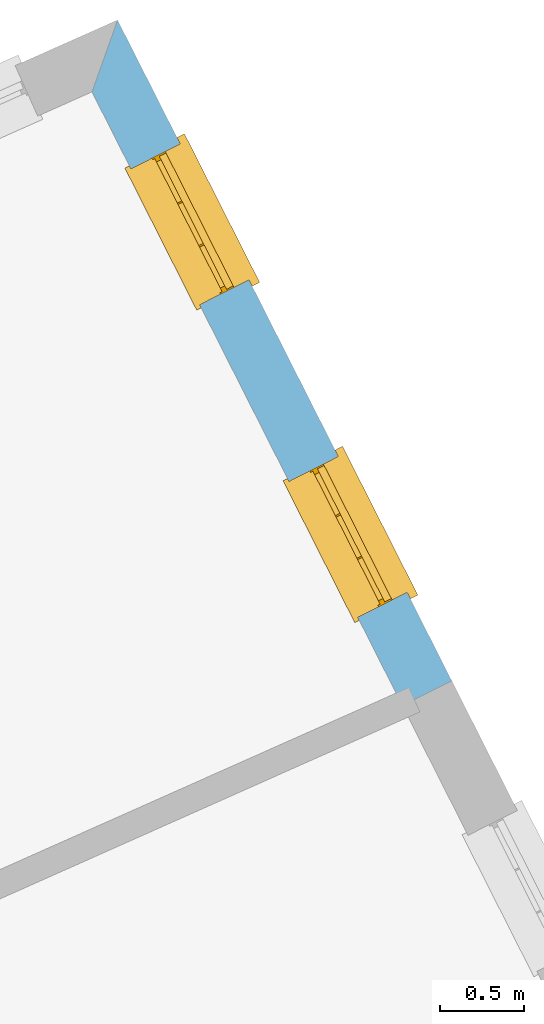
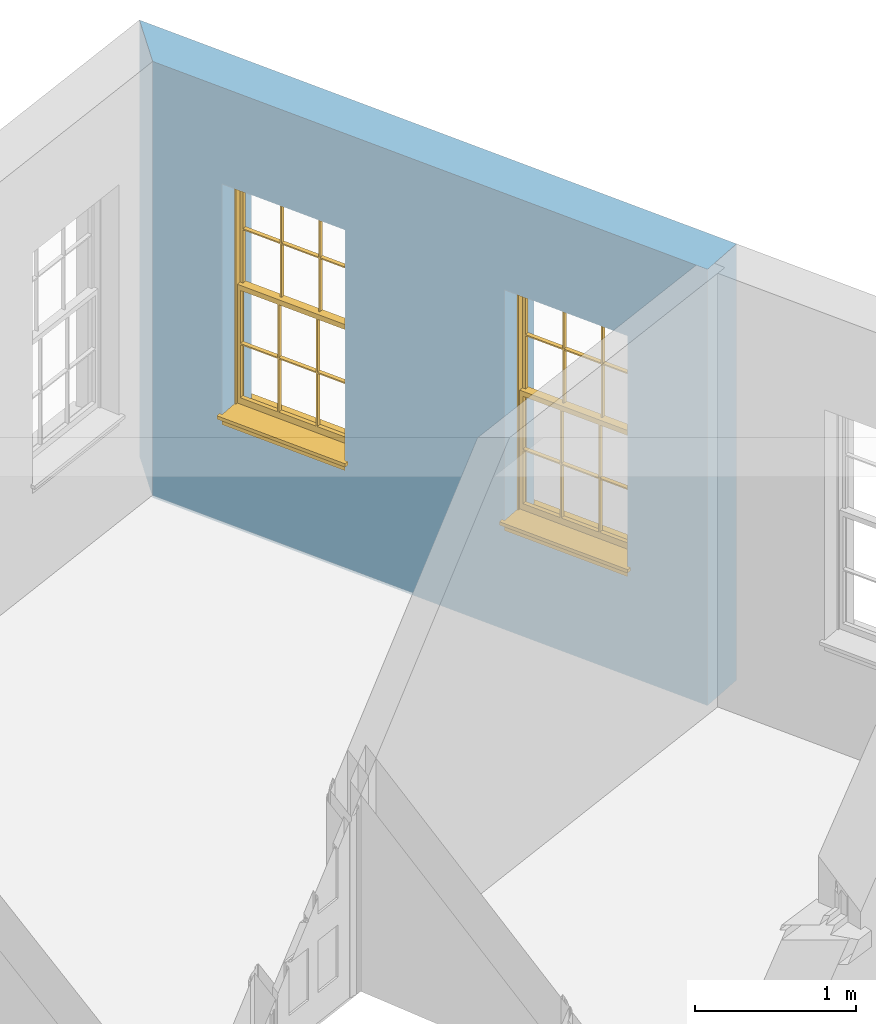
# One storey, part 8 of 8: 2 windows, 2 openings, plus 1 element that does not belong to this part.
"""IFC2X3 building model written with IfcOpenShell, lengths in metres."""

from ifc_helpers import new_model, si_unit, frame, origin, place, context, subcontext, project, spatial, polyline, outline, extrude, faceted_brep, material, layer, layer_set, layer_usage, element, fill, save


model = new_model("IFC2X3")

# Units and contexts
model_context = context("Model", 3, world=origin())
body_context = subcontext(model_context, "Body", "Model", "MODEL_VIEW")
ifc_project = project(units=[si_unit("PLANEANGLEUNIT", "RADIAN"), si_unit("MASSUNIT", "GRAM", prefix="KILO"), si_unit("FORCEUNIT", "NEWTON", prefix="KILO"), si_unit("LENGTHUNIT", "METRE")], contexts=[model_context])

# Site, building, storey
site_placement = place(None, origin())
site = spatial("IfcSite", under=ifc_project, at=site_placement, CompositionType="ELEMENT")
building_placement = place(None, origin())
building = spatial("IfcBuilding", under=site, at=building_placement, Name="Building plot-1", CompositionType="ELEMENT")
storey_placement = place(None, frame((0.0, 0.0, 5.15)))
storey = spatial("IfcBuildingStorey", under=building, at=storey_placement, Name="Floor 1", CompositionType="ELEMENT", Elevation=5.15)

# Wall, openings, windows
ifc_material = material(Name="Masonry")
ifc_layer = layer(ifc_material, 0.33, ventilated=False)
ifc_layer_set = layer_set([ifc_layer], Name="My Wall")
ifc_layer_usage = layer_usage(ifc_layer_set, "AXIS2", "NEGATIVE", 0.08)
wall_placement = place(storey_placement, origin())
wall = element("IfcWallStandardCase", 1, at=wall_placement, inside=storey, material=ifc_layer_usage, Name="exterior", context=body_context, shape_type="SweptSolid", body=[
    extrude(outline(polyline([(31.083799749939, 47.0080028311663), (31.3782721430408, 47.1569525196551), (29.383242432719, 51.1011109738831), (29.2305507452247, 50.6718619165302), (31.083799749939, 47.0080028311663)])), origin(), (0.0, 0.0, 1.0), 3.3),
])
opening_1_placement = place(storey_placement, frame((0.0, 0.0, 0.75)))
opening_1 = element("IfcOpeningElement", 2, at=opening_1_placement, cuts=wall, Name="Opening", ObjectType="Opening", context=body_context, shape_type="SweptSolid", body=[
    extrude(outline(polyline([(31.111737146863, 47.6838901652868), (30.7009970967879, 48.4959200977797), (30.4065247036861, 48.3469704092909), (30.8172647537612, 47.5349404767981), (31.111737146863, 47.6838901652868)])), origin(), (0.0, 0.0, 1.0), 1.82),
])
opening_2_placement = place(storey_placement, frame((0.0, 0.0, 0.75)))
opening_2 = element("IfcOpeningElement", 3, at=opening_2_placement, cuts=wall, Name="Opening", ObjectType="Opening", context=body_context, shape_type="SweptSolid", body=[
    extrude(outline(polyline([(30.1679271044322, 49.5497953890432), (29.7571870543571, 50.3618253215361), (29.4627146612553, 50.2128756330473), (29.8734547113304, 49.4008457005545), (30.1679271044322, 49.5497953890432)])), origin(), (0.0, 0.0, 1.0), 1.82),
])
window_1_placement = place(storey_placement, frame((30.8886520005738, 47.5710494921893, 0.75), z_axis=(0.0, 0.0, 1.0), x_axis=(-0.410740050075116, 0.81202993249282, 0.0)))
window_1 = element("IfcWindow", 4, at=window_1_placement, inside=storey, Name="living outside window", OverallHeight=1.82, OverallWidth=0.91, context=body_context, shape_type="Brep", held_by="IfcProductRepresentation", body=[
    faceted_brep([(0.033125, -0.105, 0.975209), (0.01, -0.105, 0.975209), (0.033125, -0.105, 1.376042), (0.876875, -0.105, 0.975209), (0.876875, -0.105, 1.376042), (0.9, -0.105, 0.975209), (0.876875, -0.105, 1.386042), (0.876875, -0.105, 1.786875), (0.9, -0.105, 1.81), (0.033125, -0.105, 1.786875), (0.033125, -0.105, 1.386042), (0.01, -0.105, 1.81), (0.876875, -0.135, 1.376042), (0.876875, -0.135, 0.975209), (0.9, -0.135, 0.937083), (0.033125, -0.135, 1.786875), (0.01, -0.135, 1.81), (0.033125, -0.135, 1.386042), (0.01, -0.135, 0.937083), (0.033125, -0.135, 0.975209), (0.033125, -0.135, 1.376042), (0.876875, -0.135, 1.786875), (0.876875, -0.135, 1.386042), (0.9, -0.135, 1.81), (0.033125, -0.105, 0.937083), (0.01, -0.105, 0.937083), (0.033125, -0.105, 0.53625), (0.876875, -0.105, 0.937083), (0.876875, -0.105, 0.53625), (0.9, -0.105, 0.937083), (0.876875, -0.105, 0.52625), (0.876875, -0.105, 0.125417), (0.9, -0.105, 0.077167), (0.033125, -0.105, 0.125417), (0.033125, -0.105, 0.52625), (0.01, -0.105, 0.077167), (-0.0425, -0.25, 0.01), (-0.0425, -0.3, 0.001667), (0.0, -0.25, 0.01), (0.9525, -0.25, 0.01), (0.91, -0.25, 0.01), (0.9525, -0.3, 0.001667), (-0.02, 0.08, 0.077167), (0.0, 0.08, 0.077167), (-0.02, 0.11, 0.077167), (0.0, -0.06, 0.077167), (0.01, -0.06, 0.077167), (0.91, -0.06, 0.077167), (0.91, 0.08, 0.077167), (0.9, -0.06, 0.077167), (0.93, 0.08, 0.077167), (0.93, 0.11, 0.077167), (0.01, -0.075, 0.975209), (0.9, -0.075, 0.975209), (0.876875, -0.075, 0.125417), (0.876875, -0.075, 0.52625), (0.9, -0.075, 0.077167), (0.876875, -0.075, 0.53625), (0.876875, -0.075, 0.937083), (0.033125, -0.075, 0.125417), (0.01, -0.075, 0.077167), (0.033125, -0.075, 0.52625), (0.033125, -0.075, 0.937083), (0.033125, -0.075, 0.53625), (-0.02, 0.08, 0.052167), (-0.02, 0.11, 0.052167), (0.93, 0.11, 0.052167), (0.93, 0.08, 0.052167), (0.91, 0.08, 0.052167), (0.0, 0.08, 0.052167), (0.91, -0.15, 0.026667), (0.0, -0.15, 0.026667), (-0.0425, -0.3, -0.123333), (0.9525, -0.3, -0.123333), (-0.0425, -0.25, -0.123333), (0.9525, -0.25, -0.123333), (0.01, -0.06, 1.81), (0.9, -0.06, 1.81), (0.0, -0.06, 1.82), (0.91, -0.06, 1.82), (0.01, -0.15, 0.077167), (0.9, -0.15, 0.077167), (0.592292, -0.105, 0.125417), (0.592292, -0.075, 0.125417), (0.317708, -0.075, 0.125417), (0.317708, -0.105, 0.125417), (0.592292, -0.105, 0.53625), (0.317708, -0.105, 0.53625), (0.317708, -0.105, 0.52625), (0.592292, -0.105, 0.52625), (0.592292, -0.075, 0.53625), (0.317708, -0.075, 0.53625), (0.592292, -0.135, 1.386042), (0.592292, -0.105, 1.386042), (0.317708, -0.105, 1.386042), (0.317708, -0.135, 1.386042), (0.317708, -0.135, 1.376042), (0.592292, -0.135, 1.376042), (0.317708, -0.105, 1.376042), (0.592292, -0.105, 1.376042), (0.602292, -0.135, 1.376042), (0.592292, -0.135, 0.975209), (0.602292, -0.135, 0.975209), (0.602292, -0.105, 0.975209), (0.592292, -0.105, 0.975209), (0.602292, -0.105, 1.376042), (0.602292, -0.075, 0.53625), (0.602292, -0.105, 0.53625), (0.317708, -0.075, 0.52625), (0.307708, -0.075, 0.125417), (0.307708, -0.075, 0.52625), (0.602292, -0.075, 0.52625), (0.602292, -0.075, 0.125417), (0.592292, -0.075, 0.52625), (0.307708, -0.075, 0.53625), (0.317708, -0.075, 0.937083), (0.307708, -0.075, 0.937083), (0.602292, -0.075, 0.937083), (0.592292, -0.075, 0.937083), (0.307708, -0.105, 0.52625), (0.307708, -0.105, 0.125417), (0.307708, -0.105, 0.53625), (0.307708, -0.105, 0.937083), (0.592292, -0.105, 0.937083), (0.317708, -0.105, 0.937083), (0.602292, -0.105, 0.937083), (0.602292, -0.105, 0.52625), (0.602292, -0.105, 0.125417), (0.307708, -0.135, 1.386042), (0.307708, -0.135, 1.376042), (0.307708, -0.135, 0.975209), (0.317708, -0.135, 0.975209), (0.317708, -0.135, 1.786875), (0.307708, -0.135, 1.786875), (0.602292, -0.135, 1.786875), (0.592292, -0.135, 1.786875), (0.602292, -0.135, 1.386042), (0.602292, -0.105, 1.386042), (0.307708, -0.105, 1.386042), (0.307708, -0.105, 1.786875), (0.317708, -0.105, 1.786875), (0.592292, -0.105, 1.786875), (0.602292, -0.105, 1.786875), (0.307708, -0.105, 1.376042), (0.317708, -0.105, 0.975209), (0.307708, -0.105, 0.975209), (0.91, -0.15, 1.82), (0.9, -0.15, 1.81), (0.01, -0.15, 1.81), (0.0, -0.15, 1.82), (0.91, -0.25, 0.0), (0.0, -0.25, 0.0), (0.91, 0.08, 0.0), (0.0, 0.08, 0.0)], [[[0, 1, 2]], [[3, 4, 5]], [[6, 7, 8]], [[9, 10, 11]], [[12, 13, 14]], [[15, 16, 17]], [[18, 19, 20]], [[21, 22, 23]], [[24, 25, 26]], [[27, 28, 29]], [[30, 31, 32]], [[33, 34, 35]], [[14, 27, 29]], [[25, 24, 18]], [[36, 37, 38]], [[39, 40, 41]], [[42, 43, 44]], [[45, 46, 43]], [[47, 48, 49]], [[50, 51, 48]], [[1, 0, 52]], [[5, 53, 3]], [[54, 55, 56]], [[57, 58, 53]], [[59, 60, 61]], [[62, 63, 52]], [[48, 43, 46, 49]], [[51, 44, 43, 48]], [[64, 42, 44, 65]], [[65, 44, 51, 66]], [[66, 51, 50, 67]], [[65, 66, 68, 69]], [[60, 56, 49, 46]], [[70, 71, 38, 40]], [[37, 41, 40, 38]], [[37, 72, 73, 41]], [[74, 75, 73, 72]], [[8, 11, 76, 77]], [[76, 78, 79, 77]], [[32, 35, 80, 81]], [[81, 80, 71, 70]], [[82, 83, 84, 85]], [[86, 87, 88, 89]], [[86, 90, 91, 87]], [[92, 93, 94, 95]], [[92, 95, 96, 97]], [[96, 98, 99, 97]], [[100, 97, 101, 102]], [[103, 104, 99, 105]], [[97, 99, 104, 101]], [[102, 103, 105, 100]], [[28, 57, 106, 107]], [[108, 84, 109, 110]], [[111, 112, 83, 113]], [[114, 110, 61, 63]], [[90, 113, 108, 91]], [[115, 91, 114, 116]], [[117, 106, 90, 118]], [[111, 106, 57, 55]], [[119, 110, 109, 120]], [[34, 61, 110, 119]], [[89, 113, 83, 82]], [[88, 108, 113, 89]], [[85, 84, 108, 88]], [[121, 114, 63, 26]], [[122, 116, 114, 121]], [[123, 118, 90, 86]], [[87, 91, 115, 124]], [[107, 106, 117, 125]], [[126, 111, 55, 30]], [[127, 112, 111, 126]], [[126, 30, 28, 107]], [[88, 119, 120, 85]], [[126, 89, 82, 127]], [[125, 123, 86, 107]], [[121, 26, 34, 119]], [[124, 122, 121, 87]], [[128, 17, 20, 129]], [[96, 129, 130, 131]], [[132, 133, 128, 95]], [[134, 135, 92, 136]], [[100, 12, 22, 136]], [[137, 6, 4, 105]], [[94, 138, 139, 140]], [[137, 93, 141, 142]], [[99, 98, 94, 93]], [[143, 2, 10, 138]], [[144, 145, 143, 98]], [[129, 143, 145, 130]], [[20, 2, 143, 129]], [[131, 144, 98, 96]], [[128, 138, 10, 17]], [[133, 139, 138, 128]], [[135, 141, 93, 92]], [[95, 94, 140, 132]], [[22, 6, 137, 136]], [[136, 137, 142, 134]], [[100, 105, 4, 12]], [[107, 86, 89, 126]], [[106, 111, 113, 90]], [[91, 108, 110, 114]], [[87, 121, 119, 88]], [[97, 100, 136, 92]], [[129, 96, 95, 128]], [[98, 143, 138, 94]], [[105, 99, 93, 137]], [[131, 101, 104, 144]], [[124, 115, 118, 123]], [[132, 140, 141, 135]], [[120, 109, 59, 33]], [[15, 9, 139, 133]], [[134, 142, 7, 21]], [[31, 54, 112, 127]], [[36, 74, 72, 37]], [[39, 41, 73, 75]], [[18, 14, 101, 131]], [[23, 16, 132, 135]], [[83, 56, 60, 84]], [[52, 53, 118, 115]], [[53, 52, 144, 104]], [[11, 8, 141, 140]], [[14, 18, 124, 123]], [[2, 1, 11, 10]], [[8, 5, 4, 6]], [[57, 53, 56, 55]], [[60, 52, 63, 61]], [[26, 25, 35, 34]], [[32, 29, 28, 30]], [[14, 23, 22, 12]], [[18, 20, 17, 16]], [[19, 0, 2, 20]], [[17, 10, 9, 15]], [[12, 4, 3, 13]], [[21, 7, 6, 22]], [[27, 58, 57, 28]], [[30, 55, 54, 31]], [[33, 59, 61, 34]], [[26, 63, 62, 24]], [[5, 8, 77, 53]], [[76, 11, 1, 52]], [[46, 45, 78, 76]], [[49, 77, 79, 47]], [[70, 146, 147, 81]], [[71, 80, 148, 149]], [[19, 130, 145, 0]], [[102, 13, 3, 103]], [[116, 122, 24, 62]], [[29, 32, 81, 14]], [[80, 35, 25, 18]], [[60, 46, 76, 52]], [[77, 49, 56, 53]], [[23, 14, 81, 147]], [[16, 148, 80, 18]], [[35, 85, 120]], [[120, 33, 35]], [[127, 82, 32]], [[32, 31, 127]], [[32, 82, 85, 35]], [[102, 101, 14]], [[14, 13, 102]], [[18, 131, 130]], [[130, 19, 18]], [[134, 21, 23]], [[23, 135, 134]], [[16, 15, 133]], [[133, 132, 16]], [[11, 140, 139]], [[139, 9, 11]], [[142, 141, 8]], [[8, 7, 142]], [[23, 147, 148, 16]], [[146, 149, 148, 147]], [[52, 115, 116]], [[116, 62, 52]], [[118, 53, 117]], [[58, 117, 53]], [[27, 125, 117, 58]], [[56, 83, 112]], [[112, 54, 56]], [[109, 84, 60]], [[60, 59, 109]], [[125, 27, 14]], [[14, 123, 125]], [[122, 124, 18]], [[18, 24, 122]], [[145, 144, 52]], [[52, 0, 145]], [[103, 3, 53]], [[53, 104, 103]], [[79, 78, 149, 146]], [[78, 45, 71, 149]], [[146, 70, 47, 79]], [[150, 75, 74, 151]], [[68, 66, 67]], [[48, 68, 67, 50]], [[69, 64, 65]], [[42, 64, 69, 43]], [[69, 68, 152, 153]], [[70, 68, 48, 47]], [[150, 152, 68, 70]], [[43, 69, 71, 45]], [[69, 153, 151, 71]], [[152, 150, 151, 153]], [[38, 151, 74, 36]], [[71, 151, 38]], [[39, 75, 150, 40]], [[40, 150, 70]]]),
])
fill(opening_1, window_1)
window_2_placement = place(storey_placement, frame((29.944841958143, 49.4369547159457, 0.75), z_axis=(0.0, 0.0, 1.0), x_axis=(-0.410740050075116, 0.81202993249282, 0.0)))
window_2 = element("IfcWindow", 5, at=window_2_placement, inside=storey, Name="living outside window", OverallHeight=1.82, OverallWidth=0.91, context=body_context, shape_type="Brep", held_by="IfcProductRepresentation", body=[
    faceted_brep([(0.033125, -0.105, 0.975209), (0.01, -0.105, 0.975209), (0.033125, -0.105, 1.376042), (0.876875, -0.105, 0.975209), (0.876875, -0.105, 1.376042), (0.9, -0.105, 0.975209), (0.876875, -0.105, 1.386042), (0.876875, -0.105, 1.786875), (0.9, -0.105, 1.81), (0.033125, -0.105, 1.786875), (0.033125, -0.105, 1.386042), (0.01, -0.105, 1.81), (0.876875, -0.135, 1.376042), (0.876875, -0.135, 0.975209), (0.9, -0.135, 0.937083), (0.033125, -0.135, 1.786875), (0.01, -0.135, 1.81), (0.033125, -0.135, 1.386042), (0.01, -0.135, 0.937083), (0.033125, -0.135, 0.975209), (0.033125, -0.135, 1.376042), (0.876875, -0.135, 1.786875), (0.876875, -0.135, 1.386042), (0.9, -0.135, 1.81), (0.033125, -0.105, 0.937083), (0.01, -0.105, 0.937083), (0.033125, -0.105, 0.53625), (0.876875, -0.105, 0.937083), (0.876875, -0.105, 0.53625), (0.9, -0.105, 0.937083), (0.876875, -0.105, 0.52625), (0.876875, -0.105, 0.125417), (0.9, -0.105, 0.077167), (0.033125, -0.105, 0.125417), (0.033125, -0.105, 0.52625), (0.01, -0.105, 0.077167), (-0.0425, -0.25, 0.01), (-0.0425, -0.3, 0.001667), (0.0, -0.25, 0.01), (0.9525, -0.25, 0.01), (0.91, -0.25, 0.01), (0.9525, -0.3, 0.001667), (-0.02, 0.08, 0.077167), (0.0, 0.08, 0.077167), (-0.02, 0.11, 0.077167), (0.0, -0.06, 0.077167), (0.01, -0.06, 0.077167), (0.91, -0.06, 0.077167), (0.91, 0.08, 0.077167), (0.9, -0.06, 0.077167), (0.93, 0.08, 0.077167), (0.93, 0.11, 0.077167), (0.01, -0.075, 0.975209), (0.9, -0.075, 0.975209), (0.876875, -0.075, 0.125417), (0.876875, -0.075, 0.52625), (0.9, -0.075, 0.077167), (0.876875, -0.075, 0.53625), (0.876875, -0.075, 0.937083), (0.033125, -0.075, 0.125417), (0.01, -0.075, 0.077167), (0.033125, -0.075, 0.52625), (0.033125, -0.075, 0.937083), (0.033125, -0.075, 0.53625), (-0.02, 0.08, 0.052167), (-0.02, 0.11, 0.052167), (0.93, 0.11, 0.052167), (0.93, 0.08, 0.052167), (0.91, 0.08, 0.052167), (0.0, 0.08, 0.052167), (0.91, -0.15, 0.026667), (0.0, -0.15, 0.026667), (-0.0425, -0.3, -0.123333), (0.9525, -0.3, -0.123333), (-0.0425, -0.25, -0.123333), (0.9525, -0.25, -0.123333), (0.01, -0.06, 1.81), (0.9, -0.06, 1.81), (0.0, -0.06, 1.82), (0.91, -0.06, 1.82), (0.01, -0.15, 0.077167), (0.9, -0.15, 0.077167), (0.592292, -0.105, 0.125417), (0.592292, -0.075, 0.125417), (0.317708, -0.075, 0.125417), (0.317708, -0.105, 0.125417), (0.592292, -0.105, 0.53625), (0.317708, -0.105, 0.53625), (0.317708, -0.105, 0.52625), (0.592292, -0.105, 0.52625), (0.592292, -0.075, 0.53625), (0.317708, -0.075, 0.53625), (0.592292, -0.135, 1.386042), (0.592292, -0.105, 1.386042), (0.317708, -0.105, 1.386042), (0.317708, -0.135, 1.386042), (0.317708, -0.135, 1.376042), (0.592292, -0.135, 1.376042), (0.317708, -0.105, 1.376042), (0.592292, -0.105, 1.376042), (0.602292, -0.135, 1.376042), (0.592292, -0.135, 0.975209), (0.602292, -0.135, 0.975209), (0.602292, -0.105, 0.975209), (0.592292, -0.105, 0.975209), (0.602292, -0.105, 1.376042), (0.602292, -0.075, 0.53625), (0.602292, -0.105, 0.53625), (0.317708, -0.075, 0.52625), (0.307708, -0.075, 0.125417), (0.307708, -0.075, 0.52625), (0.602292, -0.075, 0.52625), (0.602292, -0.075, 0.125417), (0.592292, -0.075, 0.52625), (0.307708, -0.075, 0.53625), (0.317708, -0.075, 0.937083), (0.307708, -0.075, 0.937083), (0.602292, -0.075, 0.937083), (0.592292, -0.075, 0.937083), (0.307708, -0.105, 0.52625), (0.307708, -0.105, 0.125417), (0.307708, -0.105, 0.53625), (0.307708, -0.105, 0.937083), (0.592292, -0.105, 0.937083), (0.317708, -0.105, 0.937083), (0.602292, -0.105, 0.937083), (0.602292, -0.105, 0.52625), (0.602292, -0.105, 0.125417), (0.307708, -0.135, 1.386042), (0.307708, -0.135, 1.376042), (0.307708, -0.135, 0.975209), (0.317708, -0.135, 0.975209), (0.317708, -0.135, 1.786875), (0.307708, -0.135, 1.786875), (0.602292, -0.135, 1.786875), (0.592292, -0.135, 1.786875), (0.602292, -0.135, 1.386042), (0.602292, -0.105, 1.386042), (0.307708, -0.105, 1.386042), (0.307708, -0.105, 1.786875), (0.317708, -0.105, 1.786875), (0.592292, -0.105, 1.786875), (0.602292, -0.105, 1.786875), (0.307708, -0.105, 1.376042), (0.317708, -0.105, 0.975209), (0.307708, -0.105, 0.975209), (0.91, -0.15, 1.82), (0.9, -0.15, 1.81), (0.01, -0.15, 1.81), (0.0, -0.15, 1.82), (0.91, -0.25, 0.0), (0.0, -0.25, 0.0), (0.91, 0.08, 0.0), (0.0, 0.08, 0.0)], [[[0, 1, 2]], [[3, 4, 5]], [[6, 7, 8]], [[9, 10, 11]], [[12, 13, 14]], [[15, 16, 17]], [[18, 19, 20]], [[21, 22, 23]], [[24, 25, 26]], [[27, 28, 29]], [[30, 31, 32]], [[33, 34, 35]], [[14, 27, 29]], [[25, 24, 18]], [[36, 37, 38]], [[39, 40, 41]], [[42, 43, 44]], [[45, 46, 43]], [[47, 48, 49]], [[50, 51, 48]], [[1, 0, 52]], [[5, 53, 3]], [[54, 55, 56]], [[57, 58, 53]], [[59, 60, 61]], [[62, 63, 52]], [[48, 43, 46, 49]], [[51, 44, 43, 48]], [[64, 42, 44, 65]], [[65, 44, 51, 66]], [[66, 51, 50, 67]], [[65, 66, 68, 69]], [[60, 56, 49, 46]], [[70, 71, 38, 40]], [[37, 41, 40, 38]], [[37, 72, 73, 41]], [[74, 75, 73, 72]], [[8, 11, 76, 77]], [[76, 78, 79, 77]], [[32, 35, 80, 81]], [[81, 80, 71, 70]], [[82, 83, 84, 85]], [[86, 87, 88, 89]], [[86, 90, 91, 87]], [[92, 93, 94, 95]], [[92, 95, 96, 97]], [[96, 98, 99, 97]], [[100, 97, 101, 102]], [[103, 104, 99, 105]], [[97, 99, 104, 101]], [[102, 103, 105, 100]], [[28, 57, 106, 107]], [[108, 84, 109, 110]], [[111, 112, 83, 113]], [[114, 110, 61, 63]], [[90, 113, 108, 91]], [[115, 91, 114, 116]], [[117, 106, 90, 118]], [[111, 106, 57, 55]], [[119, 110, 109, 120]], [[34, 61, 110, 119]], [[89, 113, 83, 82]], [[88, 108, 113, 89]], [[85, 84, 108, 88]], [[121, 114, 63, 26]], [[122, 116, 114, 121]], [[123, 118, 90, 86]], [[87, 91, 115, 124]], [[107, 106, 117, 125]], [[126, 111, 55, 30]], [[127, 112, 111, 126]], [[126, 30, 28, 107]], [[88, 119, 120, 85]], [[126, 89, 82, 127]], [[125, 123, 86, 107]], [[121, 26, 34, 119]], [[124, 122, 121, 87]], [[128, 17, 20, 129]], [[96, 129, 130, 131]], [[132, 133, 128, 95]], [[134, 135, 92, 136]], [[100, 12, 22, 136]], [[137, 6, 4, 105]], [[94, 138, 139, 140]], [[137, 93, 141, 142]], [[99, 98, 94, 93]], [[143, 2, 10, 138]], [[144, 145, 143, 98]], [[129, 143, 145, 130]], [[20, 2, 143, 129]], [[131, 144, 98, 96]], [[128, 138, 10, 17]], [[133, 139, 138, 128]], [[135, 141, 93, 92]], [[95, 94, 140, 132]], [[22, 6, 137, 136]], [[136, 137, 142, 134]], [[100, 105, 4, 12]], [[107, 86, 89, 126]], [[106, 111, 113, 90]], [[91, 108, 110, 114]], [[87, 121, 119, 88]], [[97, 100, 136, 92]], [[129, 96, 95, 128]], [[98, 143, 138, 94]], [[105, 99, 93, 137]], [[131, 101, 104, 144]], [[124, 115, 118, 123]], [[132, 140, 141, 135]], [[120, 109, 59, 33]], [[15, 9, 139, 133]], [[134, 142, 7, 21]], [[31, 54, 112, 127]], [[36, 74, 72, 37]], [[39, 41, 73, 75]], [[18, 14, 101, 131]], [[23, 16, 132, 135]], [[83, 56, 60, 84]], [[52, 53, 118, 115]], [[53, 52, 144, 104]], [[11, 8, 141, 140]], [[14, 18, 124, 123]], [[2, 1, 11, 10]], [[8, 5, 4, 6]], [[57, 53, 56, 55]], [[60, 52, 63, 61]], [[26, 25, 35, 34]], [[32, 29, 28, 30]], [[14, 23, 22, 12]], [[18, 20, 17, 16]], [[19, 0, 2, 20]], [[17, 10, 9, 15]], [[12, 4, 3, 13]], [[21, 7, 6, 22]], [[27, 58, 57, 28]], [[30, 55, 54, 31]], [[33, 59, 61, 34]], [[26, 63, 62, 24]], [[5, 8, 77, 53]], [[76, 11, 1, 52]], [[46, 45, 78, 76]], [[49, 77, 79, 47]], [[70, 146, 147, 81]], [[71, 80, 148, 149]], [[19, 130, 145, 0]], [[102, 13, 3, 103]], [[116, 122, 24, 62]], [[29, 32, 81, 14]], [[80, 35, 25, 18]], [[60, 46, 76, 52]], [[77, 49, 56, 53]], [[23, 14, 81, 147]], [[16, 148, 80, 18]], [[35, 85, 120]], [[120, 33, 35]], [[127, 82, 32]], [[32, 31, 127]], [[32, 82, 85, 35]], [[102, 101, 14]], [[14, 13, 102]], [[18, 131, 130]], [[130, 19, 18]], [[134, 21, 23]], [[23, 135, 134]], [[16, 15, 133]], [[133, 132, 16]], [[11, 140, 139]], [[139, 9, 11]], [[142, 141, 8]], [[8, 7, 142]], [[23, 147, 148, 16]], [[146, 149, 148, 147]], [[52, 115, 116]], [[116, 62, 52]], [[118, 53, 117]], [[58, 117, 53]], [[27, 125, 117, 58]], [[56, 83, 112]], [[112, 54, 56]], [[109, 84, 60]], [[60, 59, 109]], [[125, 27, 14]], [[14, 123, 125]], [[122, 124, 18]], [[18, 24, 122]], [[145, 144, 52]], [[52, 0, 145]], [[103, 3, 53]], [[53, 104, 103]], [[79, 78, 149, 146]], [[78, 45, 71, 149]], [[146, 70, 47, 79]], [[150, 75, 74, 151]], [[68, 66, 67]], [[48, 68, 67, 50]], [[69, 64, 65]], [[42, 64, 69, 43]], [[69, 68, 152, 153]], [[70, 68, 48, 47]], [[150, 152, 68, 70]], [[43, 69, 71, 45]], [[69, 153, 151, 71]], [[152, 150, 151, 153]], [[38, 151, 74, 36]], [[71, 151, 38]], [[39, 75, 150, 40]], [[40, 150, 70]]]),
])
fill(opening_2, window_2)

save(model, "model.ifc")
